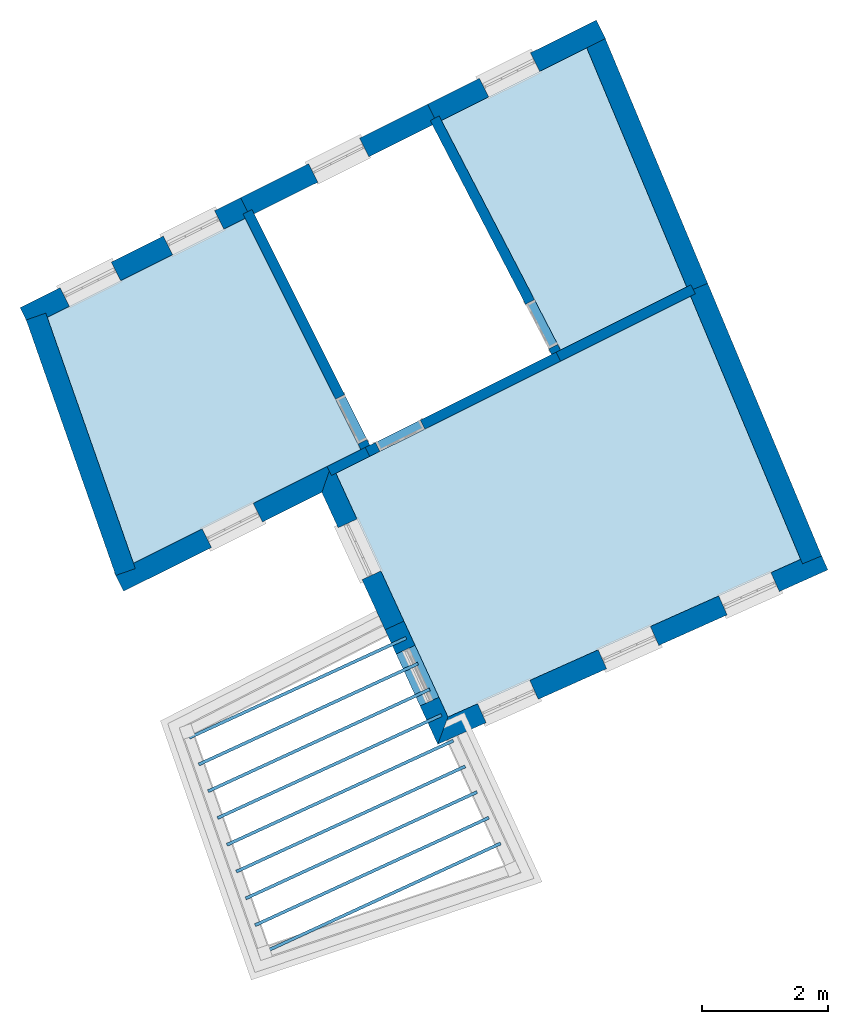
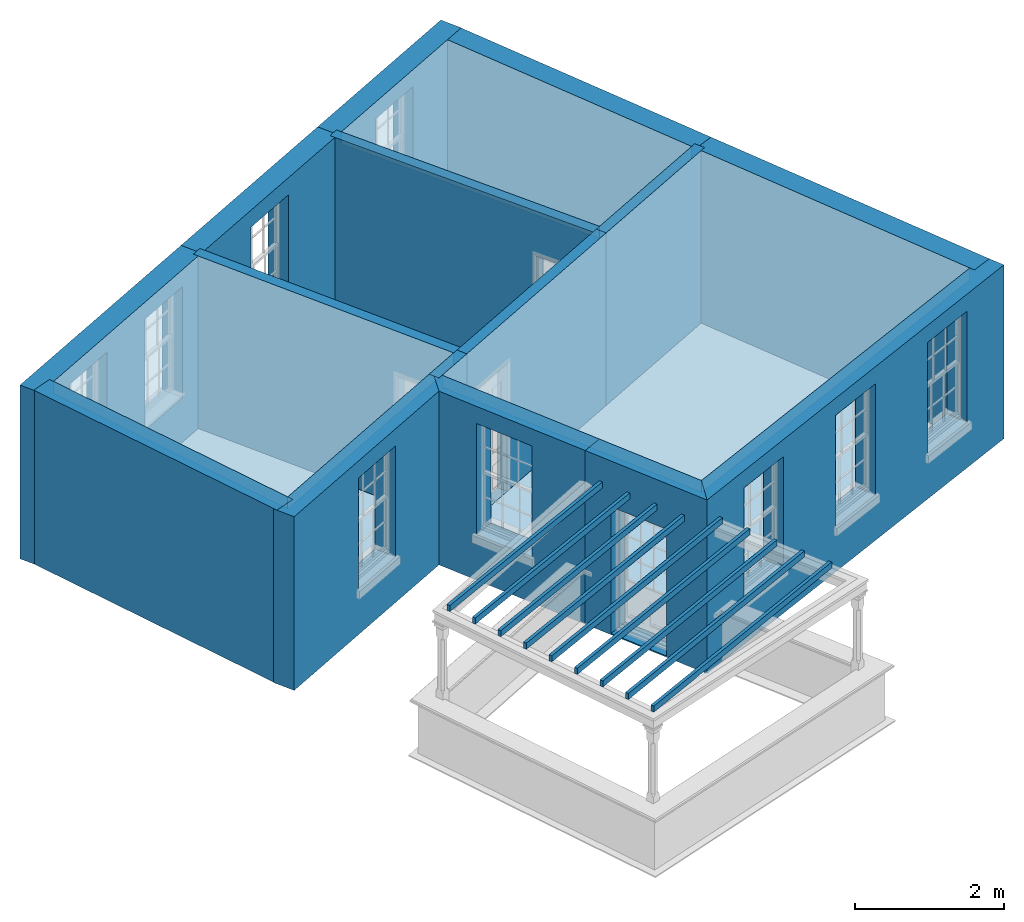
# One storey, part 1 of 9: 15 slabs, 15 walls, 13 openings.
"""IFC2X3 building model written with IfcOpenShell, lengths in metres."""

from ifc_helpers import new_model, si_unit, frame, origin, place, context, subcontext, project, spatial, polyline, outline, extrude, material, layer, layer_set, layer_usage, element, save


model = new_model("IFC2X3")

# Units and contexts
model_context = context("Model", 3, world=origin())
body_context = subcontext(model_context, "Body", "Model", "MODEL_VIEW")
ifc_project = project(units=[si_unit("PLANEANGLEUNIT", "RADIAN"), si_unit("MASSUNIT", "GRAM", prefix="KILO"), si_unit("FORCEUNIT", "NEWTON", prefix="KILO"), si_unit("LENGTHUNIT", "METRE")], contexts=[model_context])

# Site, building, storey
site_placement = place(None, origin())
site = spatial("IfcSite", under=ifc_project, at=site_placement, CompositionType="ELEMENT")
building_placement = place(None, origin())
building = spatial("IfcBuilding", under=site, at=building_placement, Name="Building plot-8", CompositionType="ELEMENT")
storey_placement = place(None, frame((0.0, 0.0, 3.45)))
storey = spatial("IfcBuildingStorey", under=building, at=storey_placement, Name="Floor 1", CompositionType="ELEMENT", Elevation=3.45)

# Slabs
slab_1_placement = place(storey_placement, frame((0.0, 0.0, 2.65)))
element("IfcSlab", 1, at=slab_1_placement, inside=storey, Name="Slab", ObjectType="Slab", PredefinedType="FLOOR", context=body_context, shape_type="SweptSolid", body=[
    extrude(outline(polyline([(31.3024320418341, 11.6441148215606), (29.5509227560087, 15.8319749374872), (23.9047363507031, 13.0131514717753), (25.6887883842839, 9.13469885839309), (31.3024320418341, 11.6441148215606)])), origin(), (0.0, 0.0, 1.0), 0.2),
])
slab_2_placement = place(storey_placement, frame((0.0, 0.0, 2.65)))
element("IfcSlab", 2, at=slab_2_placement, inside=storey, Name="Slab", ObjectType="Slab", PredefinedType="FLOOR", context=body_context, shape_type="SweptSolid", body=[
    extrude(outline(polyline([(27.480706150414, 14.9772635263), (29.4890486291312, 15.9799160247855), (27.8974321953213, 19.7854722025051), (25.5844795437758, 18.6307449687159), (27.480706150414, 14.9772635263)])), origin(), (0.0, 0.0, 1.0), 0.2),
])
slab_3_placement = place(storey_placement, frame((0.0, 0.0, 2.65)))
element("IfcSlab", 3, at=slab_3_placement, inside=storey, Name="Slab", ObjectType="Slab", PredefinedType="FLOOR", context=body_context, shape_type="SweptSolid", body=[
    extrude(outline(polyline([(22.4618389824098, 17.0717860790321), (19.3091498419461, 15.4978256230182), (20.6813816740663, 11.5827430466167), (24.3002316620791, 13.3894314080773), (22.4618389824098, 17.0717860790321)])), origin(), (0.0, 0.0, 1.0), 0.2),
])
slab_4_placement = place(storey_placement, frame((0.0, 0.0, 2.35)))
element("IfcSlab", 4, at=slab_4_placement, inside=storey, Name="Slab", ObjectType="Slab", PredefinedType="FLOOR", context=body_context, shape_type="SweptSolid", body=[
    extrude(outline(polyline([(26.5369168484507, 7.09946995719052), (26.5160219176672, 7.14489464065174), (22.7558259017705, 5.41523953911032), (22.776720832554, 5.3698148556491), (26.5369168484507, 7.09946995719052)])), origin(), (0.0, 0.0, 1.0), 0.1),
])
slab_5_placement = place(storey_placement, frame((0.0, 0.0, 2.35)))
element("IfcSlab", 5, at=slab_5_placement, inside=storey, Name="Slab", ObjectType="Slab", PredefinedType="FLOOR", context=body_context, shape_type="SweptSolid", body=[
    extrude(outline(polyline([(26.3488624713991, 7.50829210834152), (26.3279675406156, 7.55371679180274), (22.6063193071868, 5.84179331071857), (22.6272142379703, 5.79636862725735), (26.3488624713991, 7.50829210834152)])), origin(), (0.0, 0.0, 1.0), 0.1),
])
slab_6_placement = place(storey_placement, frame((0.0, 0.0, 2.35)))
element("IfcSlab", 6, at=slab_6_placement, inside=storey, Name="Slab", ObjectType="Slab", PredefinedType="FLOOR", context=body_context, shape_type="SweptSolid", body=[
    extrude(outline(polyline([(26.1608080943475, 7.91711425949251), (26.139913163564, 7.96253894295373), (22.4568127126031, 6.26834708232682), (22.4777076433866, 6.22292239886559), (26.1608080943475, 7.91711425949251)])), origin(), (0.0, 0.0, 1.0), 0.1),
])
slab_7_placement = place(storey_placement, frame((0.0, 0.0, 2.35)))
element("IfcSlab", 7, at=slab_7_placement, inside=storey, Name="Slab", ObjectType="Slab", PredefinedType="FLOOR", context=body_context, shape_type="SweptSolid", body=[
    extrude(outline(polyline([(25.9727537172959, 8.32593641064351), (25.9518587865124, 8.37136109410473), (22.3073061180194, 6.69490085393506), (22.3282010488029, 6.64947617047384), (25.9727537172959, 8.32593641064351)])), origin(), (0.0, 0.0, 1.0), 0.1),
])
slab_8_placement = place(storey_placement, frame((0.0, 0.0, 2.35)))
element("IfcSlab", 8, at=slab_8_placement, inside=storey, Name="Slab", ObjectType="Slab", PredefinedType="FLOOR", context=body_context, shape_type="SweptSolid", body=[
    extrude(outline(polyline([(25.7846993402443, 8.7347585617945), (25.7638044094607, 8.78018324525572), (22.1577995234357, 7.12145462554332), (22.1786944542192, 7.07602994208209), (25.7846993402443, 8.7347585617945)])), origin(), (0.0, 0.0, 1.0), 0.1),
])
slab_9_placement = place(storey_placement, frame((0.0, 0.0, 2.35)))
element("IfcSlab", 9, at=slab_9_placement, inside=storey, Name="Slab", ObjectType="Slab", PredefinedType="FLOOR", context=body_context, shape_type="SweptSolid", body=[
    extrude(outline(polyline([(25.5966449631926, 9.14358071294549), (25.5757500324091, 9.18900539640672), (22.008292928852, 7.54800839715156), (22.0291878596355, 7.50258371369034), (25.5966449631926, 9.14358071294549)])), origin(), (0.0, 0.0, 1.0), 0.1),
])
slab_10_placement = place(storey_placement, frame((0.0, 0.0, 2.35)))
element("IfcSlab", 10, at=slab_10_placement, inside=storey, Name="Slab", ObjectType="Slab", PredefinedType="FLOOR", context=body_context, shape_type="SweptSolid", body=[
    extrude(outline(polyline([(25.408590586141, 9.55240286409649), (25.3876956553575, 9.59782754755771), (21.8587863342683, 7.97456216875981), (21.8796812650518, 7.92913748529859), (25.408590586141, 9.55240286409649)])), origin(), (0.0, 0.0, 1.0), 0.1),
])
slab_11_placement = place(storey_placement, frame((0.0, 0.0, 2.35)))
element("IfcSlab", 11, at=slab_11_placement, inside=storey, Name="Slab", ObjectType="Slab", PredefinedType="FLOOR", context=body_context, shape_type="SweptSolid", body=[
    extrude(outline(polyline([(25.2205362090894, 9.96122501524748), (25.1996412783059, 10.0066496987087), (21.7092797396846, 8.40111594036806), (21.7301746704681, 8.35569125690684), (25.2205362090894, 9.96122501524748)])), origin(), (0.0, 0.0, 1.0), 0.1),
])
slab_12_placement = place(storey_placement, frame((0.0, 0.0, 2.35)))
element("IfcSlab", 12, at=slab_12_placement, inside=storey, Name="Slab", ObjectType="Slab", PredefinedType="FLOOR", context=body_context, shape_type="SweptSolid", body=[
    extrude(outline(polyline([(25.0324818320378, 10.3700471663985), (25.0115869012542, 10.4154718498597), (21.5597731451009, 8.8276697119763), (21.5806680758844, 8.78224502851508), (25.0324818320378, 10.3700471663985)])), origin(), (0.0, 0.0, 1.0), 0.1),
])
slab_13_placement = place(storey_placement, origin())
element("IfcSlab", 13, at=slab_13_placement, inside=storey, Name="Slab", ObjectType="Slab", PredefinedType="FLOOR", context=body_context, shape_type="SweptSolid", body=[
    extrude(outline(polyline([(31.3024320418341, 11.6441148215606), (29.5509227560087, 15.8319749374872), (23.9047363507031, 13.0131514717753), (25.6887883842839, 9.13469885839309), (31.3024320418341, 11.6441148215606)])), origin(), (0.0, 0.0, 1.0), 0.02),
])
slab_14_placement = place(storey_placement, origin())
element("IfcSlab", 14, at=slab_14_placement, inside=storey, Name="Slab", ObjectType="Slab", PredefinedType="FLOOR", context=body_context, shape_type="SweptSolid", body=[
    extrude(outline(polyline([(27.480706150414, 14.9772635263), (29.4890486291312, 15.9799160247855), (27.8974321953213, 19.7854722025051), (25.5844795437758, 18.6307449687159), (27.480706150414, 14.9772635263)])), origin(), (0.0, 0.0, 1.0), 0.02),
])
slab_15_placement = place(storey_placement, origin())
element("IfcSlab", 15, at=slab_15_placement, inside=storey, Name="Slab", ObjectType="Slab", PredefinedType="FLOOR", context=body_context, shape_type="SweptSolid", body=[
    extrude(outline(polyline([(22.4618389824098, 17.0717860790321), (19.3091498419461, 15.4978256230182), (20.6813816740663, 11.5827430466167), (24.3002316620791, 13.3894314080773), (22.4618389824098, 17.0717860790321)])), origin(), (0.0, 0.0, 1.0), 0.02),
])

# Wall, opening
ifc_material_1 = material(Name="Masonry")
ifc_layer_1 = layer(ifc_material_1, 0.33, ventilated=False)
ifc_layer_set_1 = layer_set([ifc_layer_1], Name="My Wall")
ifc_layer_usage_1 = layer_usage(ifc_layer_set_1, "AXIS2", "NEGATIVE", 0.08)
wall_1_placement = place(storey_placement, origin())
wall_1 = element("IfcWallStandardCase", 16, at=wall_1_placement, inside=storey, material=ifc_layer_usage_1, Name="exterior", context=body_context, shape_type="SweptSolid", body=[
    extrude(outline(polyline([(20.3764991877736, 11.4305323605085), (20.5239010288899, 11.1352821323367), (23.6804146792413, 12.7111519511387), (23.8378385127795, 13.1585845025615), (20.3764991877736, 11.4305323605085)])), origin(), (0.0, 0.0, 1.0), 2.85),
])
opening_1_placement = place(storey_placement, frame((0.0, 0.0, 0.75)))
element("IfcOpeningElement", 17, at=opening_1_placement, cuts=wall_1, Name="Opening", ObjectType="Opening", context=body_context, shape_type="SweptSolid", body=[
    extrude(outline(polyline([(21.9223718965962, 11.8334600200347), (22.7365467682216, 12.2399317637189), (22.5891449271054, 12.5351819918908), (21.7749700554799, 12.1287102482065), (21.9223718965962, 11.8334600200347)])), origin(), (0.0, 0.0, 1.0), 1.82),
])

wall_2_placement = place(storey_placement, origin())
wall_2 = element("IfcWallStandardCase", 18, at=wall_2_placement, inside=storey, material=ifc_layer_usage_1, Name="exterior", context=body_context, shape_type="SweptSolid", body=[
    extrude(outline(polyline([(23.8378385127795, 13.1585845025615), (23.6804146792413, 12.7111519511387), (24.6869722630542, 10.5229389293337), (24.9867751738983, 10.6608454725049), (23.8378385127795, 13.1585845025615)])), origin(), (0.0, 0.0, 1.0), 2.85),
])
opening_2_placement = place(storey_placement, frame((0.0, 0.0, 0.75)))
element("IfcOpeningElement", 19, at=opening_2_placement, cuts=wall_2, Name="Opening", ObjectType="Opening", context=body_context, shape_type="SweptSolid", body=[
    extrude(outline(polyline([(23.9396181323413, 12.1476547598287), (24.3199058726013, 11.3209255208344), (24.6197087834453, 11.4588320640056), (24.2394210431854, 12.2855613029998), (23.9396181323413, 12.1476547598287)])), origin(), (0.0, 0.0, 1.0), 1.82),
])

wall_3_placement = place(storey_placement, origin())
wall_3 = element("IfcWallStandardCase", 20, at=wall_3_placement, inside=storey, material=ifc_layer_usage_1, Name="exterior", context=body_context, shape_type="SweptSolid", body=[
    extrude(outline(polyline([(24.9867751738983, 10.6608454725049), (24.6869722630542, 10.5229389293337), (25.5254164354395, 8.70019725456561), (25.6887883842839, 9.13469885839309), (24.9867751738983, 10.6608454725049)])), origin(), (0.0, 0.0, 1.0), 2.85),
])
opening_3_placement = place(storey_placement, frame((0.0, 0.0, 0.02)))
element("IfcOpeningElement", 21, at=opening_3_placement, cuts=wall_3, Name="Opening", ObjectType="Opening", context=body_context, shape_type="SweptSolid", body=[
    extrude(outline(polyline([(24.86437208442, 10.1372793253317), (25.24465982468, 9.31055008633751), (25.544462735524, 9.44845662950871), (25.1641749952641, 10.2751858685029), (24.86437208442, 10.1372793253317)])), origin(), (0.0, 0.0, 1.0), 2.08),
])

# Wall, openings
wall_4_placement = place(storey_placement, origin())
wall_4 = element("IfcWallStandardCase", 22, at=wall_4_placement, inside=storey, material=ifc_layer_usage_1, Name="exterior", context=body_context, shape_type="SweptSolid", body=[
    extrude(outline(polyline([(25.6887883842839, 9.13469885839309), (25.5254164354395, 8.70019725456561), (31.7366248764663, 11.4767371568641), (31.6019513234471, 11.778006196291), (25.6887883842839, 9.13469885839309)])), origin(), (0.0, 0.0, 1.0), 2.85),
])
opening_4_placement = place(storey_placement, frame((0.0, 0.0, 0.75)))
element("IfcOpeningElement", 23, at=opening_4_placement, cuts=wall_4, Name="Opening", ObjectType="Opening", context=body_context, shape_type="SweptSolid", body=[
    extrude(outline(polyline([(26.2953527613871, 9.04437487338484), (27.1261249610187, 9.41574739837715), (26.9914514079996, 9.71701643780401), (26.1606792083679, 9.34564391281171), (26.2953527613871, 9.04437487338484)])), origin(), (0.0, 0.0, 1.0), 1.82),
])
opening_5_placement = place(storey_placement, frame((0.0, 0.0, 0.75)))
element("IfcOpeningElement", 24, at=opening_5_placement, cuts=wall_4, Name="Opening", ObjectType="Opening", context=body_context, shape_type="SweptSolid", body=[
    extrude(outline(polyline([(28.2144135191812, 9.90223511419651), (29.0451857188129, 10.2736076391888), (28.9105121657937, 10.5748766786157), (28.0797399661621, 10.2035041536234), (28.2144135191812, 9.90223511419651)])), origin(), (0.0, 0.0, 1.0), 1.82),
])
opening_6_placement = place(storey_placement, frame((0.0, 0.0, 0.75)))
element("IfcOpeningElement", 25, at=opening_6_placement, cuts=wall_4, Name="Opening", ObjectType="Opening", context=body_context, shape_type="SweptSolid", body=[
    extrude(outline(polyline([(30.1334742769754, 10.7600953550082), (30.9642464766071, 11.1314678800005), (30.8295729235879, 11.4327369194274), (29.9988007239562, 11.0613643944351), (30.1334742769754, 10.7600953550082)])), origin(), (0.0, 0.0, 1.0), 1.82),
])

# Wall, opening
wall_5_placement = place(storey_placement, origin())
wall_5 = element("IfcWallStandardCase", 26, at=wall_5_placement, inside=storey, material=ifc_layer_usage_1, Name="exterior", context=body_context, shape_type="SweptSolid", body=[
    extrude(outline(polyline([(28.1976396877446, 19.9353489269842), (28.0502378466283, 20.230599155156), (25.3643689149095, 18.889695786567), (25.5117707560258, 18.5944455583952), (28.1976396877446, 19.9353489269842)])), origin(), (0.0, 0.0, 1.0), 2.85),
])
opening_7_placement = place(storey_placement, frame((0.0, 0.0, 0.75)))
element("IfcOpeningElement", 27, at=opening_7_placement, cuts=wall_5, Name="Opening", ObjectType="Opening", context=body_context, shape_type="SweptSolid", body=[
    extrude(outline(polyline([(27.0025536089408, 19.7075493119778), (26.1883787373153, 19.3010775682935), (26.3357805784316, 19.0058273401217), (27.149955450057, 19.4122990838059), (27.0025536089408, 19.7075493119778)])), origin(), (0.0, 0.0, 1.0), 1.82),
])

wall_6_placement = place(storey_placement, origin())
wall_6 = element("IfcWallStandardCase", 28, at=wall_6_placement, inside=storey, material=ifc_layer_usage_1, Name="exterior", context=body_context, shape_type="SweptSolid", body=[
    extrude(outline(polyline([(25.5117707560258, 18.5944455583952), (25.3643689149095, 18.889695786567), (22.3860129541837, 17.4027700868685), (22.5334147953, 17.1075198586967), (25.5117707560258, 18.5944455583952)])), origin(), (0.0, 0.0, 1.0), 2.85),
])
opening_8_placement = place(storey_placement, frame((0.0, 0.0, 0.75)))
element("IfcOpeningElement", 29, at=opening_8_placement, cuts=wall_6, Name="Opening", ObjectType="Opening", context=body_context, shape_type="SweptSolid", body=[
    extrude(outline(polyline([(24.2822783703593, 18.3494688085599), (23.4681034987339, 17.9429970648756), (23.6155053398501, 17.6477468367038), (24.4296802114756, 18.054218580388), (24.2822783703593, 18.3494688085599)])), origin(), (0.0, 0.0, 1.0), 1.82),
])

# Wall, openings
wall_7_placement = place(storey_placement, origin())
wall_7 = element("IfcWallStandardCase", 30, at=wall_7_placement, inside=storey, material=ifc_layer_usage_1, Name="exterior", context=body_context, shape_type="SweptSolid", body=[
    extrude(outline(polyline([(22.5334147953, 17.1075198586967), (22.3860129541837, 17.4027700868685), (18.8749875286192, 15.6499124679644), (19.0223893697354, 15.3546622397925), (22.5334147953, 17.1075198586967)])), origin(), (0.0, 0.0, 1.0), 2.85),
])
opening_9_placement = place(storey_placement, frame((0.0, 0.0, 0.75)))
element("IfcOpeningElement", 31, at=opening_9_placement, cuts=wall_7, Name="Opening", ObjectType="Opening", context=body_context, shape_type="SweptSolid", body=[
    extrude(outline(polyline([(21.9712626374257, 17.1957085693475), (21.1570877658003, 16.7892368256633), (21.3044896069165, 16.4939865974914), (22.118664478542, 16.9004583411757), (21.9712626374257, 17.1957085693475)])), origin(), (0.0, 0.0, 1.0), 1.82),
])
opening_10_placement = place(storey_placement, frame((0.0, 0.0, 0.75)))
element("IfcOpeningElement", 32, at=opening_10_placement, cuts=wall_7, Name="Opening", ObjectType="Opening", context=body_context, shape_type="SweptSolid", body=[
    extrude(outline(polyline([(20.3275871322843, 16.3751137906213), (19.5134122606589, 15.9686420469371), (19.6608141017751, 15.6733918187652), (20.4749889734006, 16.0798635624495), (20.3275871322843, 16.3751137906213)])), origin(), (0.0, 0.0, 1.0), 1.82),
])

# Walls
wall_8_placement = place(storey_placement, origin())
element("IfcWallStandardCase", 33, at=wall_8_placement, inside=storey, material=ifc_layer_usage_1, Name="party", context=body_context, shape_type="SweptSolid", body=[
    extrude(outline(polyline([(19.2858269240116, 15.5643676952094), (18.9744021345431, 15.4552136732749), (20.3999795119104, 11.3879321682106), (20.7114043013789, 11.4970861901451), (19.2858269240116, 15.5643676952094)])), origin(), (0.0, 0.0, 1.0), 2.85),
])
wall_9_placement = place(storey_placement, origin())
element("IfcWallStandardCase", 34, at=wall_9_placement, inside=storey, material=ifc_layer_usage_1, Name="party", context=body_context, shape_type="SweptSolid", body=[
    extrude(outline(polyline([(31.3325603412757, 11.5720780332814), (31.6370059475429, 11.6994078130841), (29.8223626642942, 16.0382213678007), (29.517917058027, 15.910891587998), (31.3325603412757, 11.5720780332814)])), origin(), (0.0, 0.0, 1.0), 2.85),
])
wall_10_placement = place(storey_placement, origin())
element("IfcWallStandardCase", 35, at=wall_10_placement, inside=storey, material=ifc_layer_usage_1, Name="party", context=body_context, shape_type="SweptSolid", body=[
    extrude(outline(polyline([(29.517917058027, 15.910891587998), (29.8223626642942, 16.0382213678007), (28.1688721036068, 19.9917186328186), (27.8644264973396, 19.8643888530159), (29.517917058027, 15.910891587998)])), origin(), (0.0, 0.0, 1.0), 2.85),
])

# Wall, opening
ifc_material_2 = material(Name="Masonry")
ifc_layer_2 = layer(ifc_material_2, 0.16, ventilated=False)
ifc_layer_set_2 = layer_set([ifc_layer_2], Name="My Wall")
ifc_layer_usage_2 = layer_usage(ifc_layer_set_2, "AXIS2", "NEGATIVE", 0.08)
wall_11_placement = place(storey_placement, origin())
wall_11 = element("IfcWallStandardCase", 36, at=wall_11_placement, inside=storey, material=ifc_layer_usage_2, Name="interior", context=body_context, shape_type="SweptSolid", body=[
    extrude(outline(polyline([(24.3359654417437, 13.3178555951871), (24.4791170675239, 13.3893231545162), (22.5692568285255, 17.2148294512514), (22.4261052027453, 17.1433618919223), (24.3359654417437, 13.3178555951871)])), origin(), (0.0, 0.0, 1.0), 2.85),
])
opening_11_placement = place(storey_placement, frame((0.0, 0.0, 0.02)))
element("IfcOpeningElement", 37, at=opening_11_placement, cuts=wall_11, Name="Opening", ObjectType="Opening", context=body_context, shape_type="SweptSolid", body=[
    extrude(outline(polyline([(24.3987160632787, 13.5503687335191), (24.0413782666332, 14.2661268624206), (23.8982266408529, 14.1946593030915), (24.2555644374984, 13.47890117419), (24.3987160632787, 13.5503687335191)])), origin(), (0.0, 0.0, 1.0), 2.1),
])

wall_12_placement = place(storey_placement, origin())
wall_12 = element("IfcWallStandardCase", 38, at=wall_12_placement, inside=storey, material=ifc_layer_usage_2, Name="interior", context=body_context, shape_type="SweptSolid", body=[
    extrude(outline(polyline([(27.4817132172852, 14.7989349376481), (27.4102456579562, 14.9420865634283), (24.3718074749693, 13.4251651877418), (24.4432750342983, 13.2820135619616), (27.4817132172852, 14.7989349376481)])), origin(), (0.0, 0.0, 1.0), 2.85),
])
opening_12_placement = place(storey_placement, frame((0.0, 0.0, 0.02)))
element("IfcOpeningElement", 39, at=opening_12_placement, cuts=wall_12, Name="Opening", ObjectType="Opening", context=body_context, shape_type="SweptSolid", body=[
    extrude(outline(polyline([(25.2486111828736, 13.8629039886326), (24.5328530539721, 13.5055661919871), (24.6043206133012, 13.3624145662068), (25.3200787422027, 13.7197523628523), (25.2486111828736, 13.8629039886326)])), origin(), (0.0, 0.0, 1.0), 2.1),
])

wall_13_placement = place(storey_placement, origin())
wall_13 = element("IfcWallStandardCase", 40, at=wall_13_placement, inside=storey, material=ifc_layer_usage_2, Name="interior", context=body_context, shape_type="SweptSolid", body=[
    extrude(outline(polyline([(27.374973605375, 14.8336573682362), (27.5169852698664, 14.9073641328402), (25.5470428086069, 18.7028747535873), (25.4050311441155, 18.6291679889833), (27.374973605375, 14.8336573682362)])), origin(), (0.0, 0.0, 1.0), 2.85),
])
opening_13_placement = place(storey_placement, frame((0.0, 0.0, 0.02)))
element("IfcOpeningElement", 41, at=opening_13_placement, cuts=wall_13, Name="Opening", ObjectType="Opening", context=body_context, shape_type="SweptSolid", body=[
    extrude(outline(polyline([(27.4340651596868, 15.067127255393), (27.0655313366665, 15.7771855778497), (26.9235196721751, 15.7034788132456), (27.2920534951955, 14.9934204907889), (27.4340651596868, 15.067127255393)])), origin(), (0.0, 0.0, 1.0), 2.1),
])

# Walls
wall_14_placement = place(storey_placement, origin())
element("IfcWallStandardCase", 42, at=wall_14_placement, inside=storey, material=ifc_layer_usage_2, Name="interior", context=body_context, shape_type="SweptSolid", body=[
    extrude(outline(polyline([(24.4432750342983, 13.2820135619616), (24.3718074749693, 13.4251651877418), (23.76394137953, 13.121691818137), (23.835408938859, 12.9785401923568), (24.4432750342983, 13.2820135619616)])), origin(), (0.0, 0.0, 1.0), 2.85),
])
wall_15_placement = place(storey_placement, origin())
element("IfcWallStandardCase", 43, at=wall_15_placement, inside=storey, material=ifc_layer_usage_2, Name="interior", context=body_context, shape_type="SweptSolid", body=[
    extrude(outline(polyline([(27.4102456579561, 14.9420865634283), (27.4817132172853, 14.7989349376481), (29.6274558331503, 15.8701836005146), (29.5559882738211, 16.0133352262948), (27.4102456579561, 14.9420865634283)])), origin(), (0.0, 0.0, 1.0), 2.85),
])

save(model, "model.ifc")
